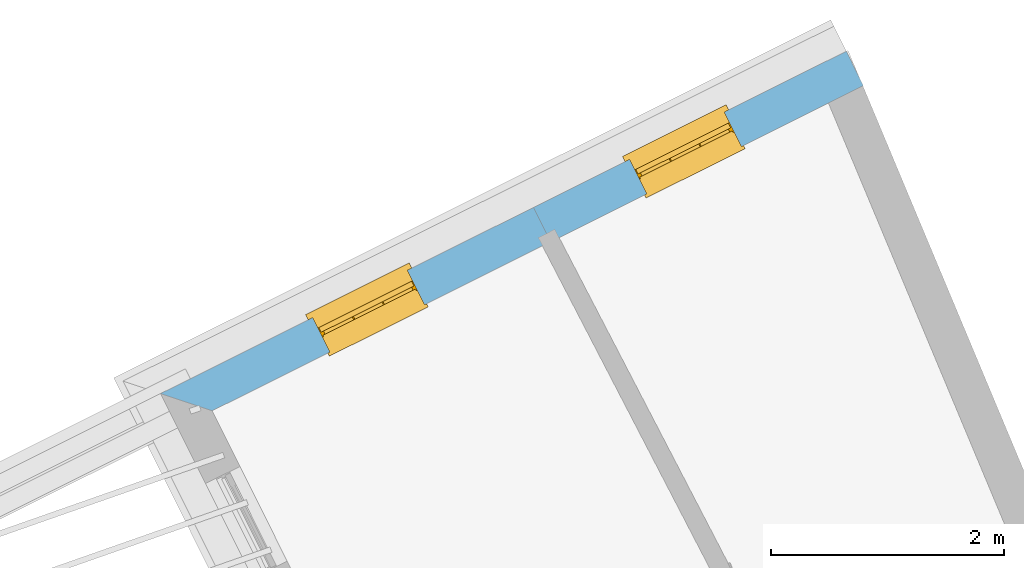
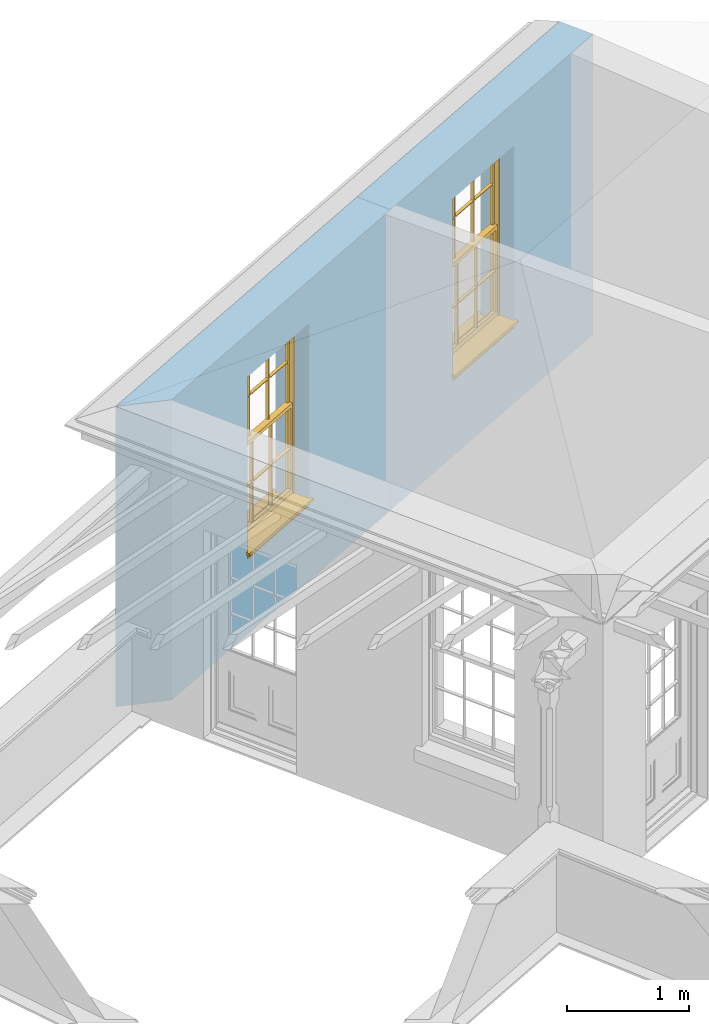
# One storey, part 5 of 7: 2 windows, 2 openings, plus 2 elements that do not belong to this part.
"""IFC2X3 building model written with IfcOpenShell, lengths in metres."""

from ifc_helpers import new_model, si_unit, frame, origin, place, context, subcontext, project, spatial, polyline, outline, extrude, faceted_brep, material, layer, layer_set, layer_usage, element, fill, save


model = new_model("IFC2X3")

# Units and contexts
model_context = context("Model", 3, world=origin())
body_context = subcontext(model_context, "Body", "Model", "MODEL_VIEW")
ifc_project = project(units=[si_unit("PLANEANGLEUNIT", "RADIAN"), si_unit("MASSUNIT", "GRAM", prefix="KILO"), si_unit("FORCEUNIT", "NEWTON", prefix="KILO"), si_unit("LENGTHUNIT", "METRE")], contexts=[model_context])

# Site, building, storey
site_placement = place(None, origin())
site = spatial("IfcSite", under=ifc_project, at=site_placement, CompositionType="ELEMENT")
building_placement = place(None, origin())
building = spatial("IfcBuilding", under=site, at=building_placement, Name="Building plot-8", CompositionType="ELEMENT")
storey_placement = place(None, frame((0.0, 0.0, 6.3)))
storey = spatial("IfcBuildingStorey", under=building, at=storey_placement, Name="Floor 2", CompositionType="ELEMENT", Elevation=6.3)

# Wall, opening, window
ifc_material = material(Name="Masonry")
ifc_layer = layer(ifc_material, 0.33, ventilated=False)
ifc_layer_set = layer_set([ifc_layer], Name="My Wall")
ifc_layer_usage = layer_usage(ifc_layer_set, "AXIS2", "NEGATIVE", 0.08)
wall_1_placement = place(storey_placement, origin())
wall_1 = element("IfcWallStandardCase", 1, at=wall_1_placement, inside=storey, material=ifc_layer_usage, Name="exterior", context=body_context, shape_type="SweptSolid", body=[
    extrude(outline(polyline([(28.1976396877446, 19.9353489269842), (28.0502378466283, 20.230599155156), (25.3643689149095, 18.889695786567), (25.5117707560258, 18.5944455583952), (28.1976396877446, 19.9353489269842)])), origin(), (0.0, 0.0, 1.0), 3.0),
])
opening_1_placement = place(storey_placement, frame((0.0, 0.0, 0.75)))
opening_1 = element("IfcOpeningElement", 2, at=opening_1_placement, cuts=wall_1, Name="Opening", ObjectType="Opening", context=body_context, shape_type="SweptSolid", body=[
    extrude(outline(polyline([(27.0025536089408, 19.7075493119778), (26.1883787373153, 19.3010775682935), (26.3357805784316, 19.0058273401217), (27.149955450057, 19.4122990838059), (27.0025536089408, 19.7075493119778)])), origin(), (0.0, 0.0, 1.0), 1.82),
])
window_1_placement = place(storey_placement, frame((27.1142216703925, 19.4838748966961, 0.75), z_axis=(0.0, 0.0, 1.0), x_axis=(-0.814174871625433, -0.406471743684243, 0.0)))
window_1 = element("IfcWindow", 3, at=window_1_placement, inside=storey, Name="bedroom outside window", OverallHeight=1.82, OverallWidth=0.91, context=body_context, shape_type="Brep", held_by="IfcProductRepresentation", body=[
    faceted_brep([(0.033125, -0.105, 0.975209), (0.01, -0.105, 0.975209), (0.033125, -0.105, 1.376042), (0.876875, -0.105, 0.975209), (0.876875, -0.105, 1.376042), (0.9, -0.105, 0.975209), (0.876875, -0.105, 1.386042), (0.876875, -0.105, 1.786875), (0.9, -0.105, 1.81), (0.033125, -0.105, 1.786875), (0.033125, -0.105, 1.386042), (0.01, -0.105, 1.81), (0.876875, -0.135, 1.376042), (0.876875, -0.135, 0.975209), (0.9, -0.135, 0.937083), (0.033125, -0.135, 1.786875), (0.01, -0.135, 1.81), (0.033125, -0.135, 1.386042), (0.01, -0.135, 0.937083), (0.033125, -0.135, 0.975209), (0.033125, -0.135, 1.376042), (0.876875, -0.135, 1.786875), (0.876875, -0.135, 1.386042), (0.9, -0.135, 1.81), (0.033125, -0.105, 0.937083), (0.01, -0.105, 0.937083), (0.033125, -0.105, 0.53625), (0.876875, -0.105, 0.937083), (0.876875, -0.105, 0.53625), (0.9, -0.105, 0.937083), (0.876875, -0.105, 0.52625), (0.876875, -0.105, 0.125417), (0.9, -0.105, 0.077167), (0.033125, -0.105, 0.125417), (0.033125, -0.105, 0.52625), (0.01, -0.105, 0.077167), (-0.0425, -0.25, 0.01), (-0.0425, -0.3, 0.001667), (0.0, -0.25, 0.01), (0.9525, -0.25, 0.01), (0.91, -0.25, 0.01), (0.9525, -0.3, 0.001667), (-0.02, 0.08, 0.077167), (0.0, 0.08, 0.077167), (-0.02, 0.11, 0.077167), (0.0, -0.06, 0.077167), (0.01, -0.06, 0.077167), (0.91, -0.06, 0.077167), (0.91, 0.08, 0.077167), (0.9, -0.06, 0.077167), (0.93, 0.08, 0.077167), (0.93, 0.11, 0.077167), (0.01, -0.075, 0.975209), (0.9, -0.075, 0.975209), (0.876875, -0.075, 0.125417), (0.876875, -0.075, 0.52625), (0.9, -0.075, 0.077167), (0.876875, -0.075, 0.53625), (0.876875, -0.075, 0.937083), (0.033125, -0.075, 0.125417), (0.01, -0.075, 0.077167), (0.033125, -0.075, 0.52625), (0.033125, -0.075, 0.937083), (0.033125, -0.075, 0.53625), (-0.02, 0.08, 0.052167), (-0.02, 0.11, 0.052167), (0.93, 0.11, 0.052167), (0.93, 0.08, 0.052167), (0.91, 0.08, 0.052167), (0.0, 0.08, 0.052167), (0.91, -0.15, 0.026667), (0.0, -0.15, 0.026667), (-0.0425, -0.3, -0.123333), (0.9525, -0.3, -0.123333), (-0.0425, -0.25, -0.123333), (0.9525, -0.25, -0.123333), (0.01, -0.06, 1.81), (0.9, -0.06, 1.81), (0.0, -0.06, 1.82), (0.91, -0.06, 1.82), (0.01, -0.15, 0.077167), (0.9, -0.15, 0.077167), (0.592292, -0.105, 0.125417), (0.592292, -0.075, 0.125417), (0.317708, -0.075, 0.125417), (0.317708, -0.105, 0.125417), (0.592292, -0.105, 0.53625), (0.317708, -0.105, 0.53625), (0.317708, -0.105, 0.52625), (0.592292, -0.105, 0.52625), (0.592292, -0.075, 0.53625), (0.317708, -0.075, 0.53625), (0.592292, -0.135, 1.386042), (0.592292, -0.105, 1.386042), (0.317708, -0.105, 1.386042), (0.317708, -0.135, 1.386042), (0.317708, -0.135, 1.376042), (0.592292, -0.135, 1.376042), (0.317708, -0.105, 1.376042), (0.592292, -0.105, 1.376042), (0.602292, -0.135, 1.376042), (0.592292, -0.135, 0.975209), (0.602292, -0.135, 0.975209), (0.602292, -0.105, 0.975209), (0.592292, -0.105, 0.975209), (0.602292, -0.105, 1.376042), (0.602292, -0.075, 0.53625), (0.602292, -0.105, 0.53625), (0.317708, -0.075, 0.52625), (0.307708, -0.075, 0.125417), (0.307708, -0.075, 0.52625), (0.602292, -0.075, 0.52625), (0.602292, -0.075, 0.125417), (0.592292, -0.075, 0.52625), (0.307708, -0.075, 0.53625), (0.317708, -0.075, 0.937083), (0.307708, -0.075, 0.937083), (0.602292, -0.075, 0.937083), (0.592292, -0.075, 0.937083), (0.307708, -0.105, 0.52625), (0.307708, -0.105, 0.125417), (0.307708, -0.105, 0.53625), (0.307708, -0.105, 0.937083), (0.592292, -0.105, 0.937083), (0.317708, -0.105, 0.937083), (0.602292, -0.105, 0.937083), (0.602292, -0.105, 0.52625), (0.602292, -0.105, 0.125417), (0.307708, -0.135, 1.386042), (0.307708, -0.135, 1.376042), (0.307708, -0.135, 0.975209), (0.317708, -0.135, 0.975209), (0.317708, -0.135, 1.786875), (0.307708, -0.135, 1.786875), (0.602292, -0.135, 1.786875), (0.592292, -0.135, 1.786875), (0.602292, -0.135, 1.386042), (0.602292, -0.105, 1.386042), (0.307708, -0.105, 1.386042), (0.307708, -0.105, 1.786875), (0.317708, -0.105, 1.786875), (0.592292, -0.105, 1.786875), (0.602292, -0.105, 1.786875), (0.307708, -0.105, 1.376042), (0.317708, -0.105, 0.975209), (0.307708, -0.105, 0.975209), (0.91, -0.15, 1.82), (0.9, -0.15, 1.81), (0.01, -0.15, 1.81), (0.0, -0.15, 1.82), (0.91, -0.25, 0.0), (0.0, -0.25, 0.0), (0.91, 0.08, 0.0), (0.0, 0.08, 0.0)], [[[0, 1, 2]], [[3, 4, 5]], [[6, 7, 8]], [[9, 10, 11]], [[12, 13, 14]], [[15, 16, 17]], [[18, 19, 20]], [[21, 22, 23]], [[24, 25, 26]], [[27, 28, 29]], [[30, 31, 32]], [[33, 34, 35]], [[14, 27, 29]], [[25, 24, 18]], [[36, 37, 38]], [[39, 40, 41]], [[42, 43, 44]], [[45, 46, 43]], [[47, 48, 49]], [[50, 51, 48]], [[1, 0, 52]], [[5, 53, 3]], [[54, 55, 56]], [[57, 58, 53]], [[59, 60, 61]], [[62, 63, 52]], [[48, 43, 46, 49]], [[51, 44, 43, 48]], [[64, 42, 44, 65]], [[65, 44, 51, 66]], [[66, 51, 50, 67]], [[65, 66, 68, 69]], [[60, 56, 49, 46]], [[70, 71, 38, 40]], [[37, 41, 40, 38]], [[37, 72, 73, 41]], [[74, 75, 73, 72]], [[8, 11, 76, 77]], [[76, 78, 79, 77]], [[32, 35, 80, 81]], [[81, 80, 71, 70]], [[82, 83, 84, 85]], [[86, 87, 88, 89]], [[86, 90, 91, 87]], [[92, 93, 94, 95]], [[92, 95, 96, 97]], [[96, 98, 99, 97]], [[100, 97, 101, 102]], [[103, 104, 99, 105]], [[97, 99, 104, 101]], [[102, 103, 105, 100]], [[28, 57, 106, 107]], [[108, 84, 109, 110]], [[111, 112, 83, 113]], [[114, 110, 61, 63]], [[90, 113, 108, 91]], [[115, 91, 114, 116]], [[117, 106, 90, 118]], [[111, 106, 57, 55]], [[119, 110, 109, 120]], [[34, 61, 110, 119]], [[89, 113, 83, 82]], [[88, 108, 113, 89]], [[85, 84, 108, 88]], [[121, 114, 63, 26]], [[122, 116, 114, 121]], [[123, 118, 90, 86]], [[87, 91, 115, 124]], [[107, 106, 117, 125]], [[126, 111, 55, 30]], [[127, 112, 111, 126]], [[126, 30, 28, 107]], [[88, 119, 120, 85]], [[126, 89, 82, 127]], [[125, 123, 86, 107]], [[121, 26, 34, 119]], [[124, 122, 121, 87]], [[128, 17, 20, 129]], [[96, 129, 130, 131]], [[132, 133, 128, 95]], [[134, 135, 92, 136]], [[100, 12, 22, 136]], [[137, 6, 4, 105]], [[94, 138, 139, 140]], [[137, 93, 141, 142]], [[99, 98, 94, 93]], [[143, 2, 10, 138]], [[144, 145, 143, 98]], [[129, 143, 145, 130]], [[20, 2, 143, 129]], [[131, 144, 98, 96]], [[128, 138, 10, 17]], [[133, 139, 138, 128]], [[135, 141, 93, 92]], [[95, 94, 140, 132]], [[22, 6, 137, 136]], [[136, 137, 142, 134]], [[100, 105, 4, 12]], [[107, 86, 89, 126]], [[106, 111, 113, 90]], [[91, 108, 110, 114]], [[87, 121, 119, 88]], [[97, 100, 136, 92]], [[129, 96, 95, 128]], [[98, 143, 138, 94]], [[105, 99, 93, 137]], [[131, 101, 104, 144]], [[124, 115, 118, 123]], [[132, 140, 141, 135]], [[120, 109, 59, 33]], [[15, 9, 139, 133]], [[134, 142, 7, 21]], [[31, 54, 112, 127]], [[36, 74, 72, 37]], [[39, 41, 73, 75]], [[18, 14, 101, 131]], [[23, 16, 132, 135]], [[83, 56, 60, 84]], [[52, 53, 118, 115]], [[53, 52, 144, 104]], [[11, 8, 141, 140]], [[14, 18, 124, 123]], [[2, 1, 11, 10]], [[8, 5, 4, 6]], [[57, 53, 56, 55]], [[60, 52, 63, 61]], [[26, 25, 35, 34]], [[32, 29, 28, 30]], [[14, 23, 22, 12]], [[18, 20, 17, 16]], [[19, 0, 2, 20]], [[17, 10, 9, 15]], [[12, 4, 3, 13]], [[21, 7, 6, 22]], [[27, 58, 57, 28]], [[30, 55, 54, 31]], [[33, 59, 61, 34]], [[26, 63, 62, 24]], [[5, 8, 77, 53]], [[76, 11, 1, 52]], [[46, 45, 78, 76]], [[49, 77, 79, 47]], [[70, 146, 147, 81]], [[71, 80, 148, 149]], [[19, 130, 145, 0]], [[102, 13, 3, 103]], [[116, 122, 24, 62]], [[29, 32, 81, 14]], [[80, 35, 25, 18]], [[60, 46, 76, 52]], [[77, 49, 56, 53]], [[23, 14, 81, 147]], [[16, 148, 80, 18]], [[35, 85, 120]], [[120, 33, 35]], [[127, 82, 32]], [[32, 31, 127]], [[32, 82, 85, 35]], [[102, 101, 14]], [[14, 13, 102]], [[18, 131, 130]], [[130, 19, 18]], [[134, 21, 23]], [[23, 135, 134]], [[16, 15, 133]], [[133, 132, 16]], [[11, 140, 139]], [[139, 9, 11]], [[142, 141, 8]], [[8, 7, 142]], [[23, 147, 148, 16]], [[146, 149, 148, 147]], [[52, 115, 116]], [[116, 62, 52]], [[118, 53, 117]], [[58, 117, 53]], [[27, 125, 117, 58]], [[56, 83, 112]], [[112, 54, 56]], [[109, 84, 60]], [[60, 59, 109]], [[125, 27, 14]], [[14, 123, 125]], [[122, 124, 18]], [[18, 24, 122]], [[145, 144, 52]], [[52, 0, 145]], [[103, 3, 53]], [[53, 104, 103]], [[79, 78, 149, 146]], [[78, 45, 71, 149]], [[146, 70, 47, 79]], [[150, 75, 74, 151]], [[68, 66, 67]], [[48, 68, 67, 50]], [[69, 64, 65]], [[42, 64, 69, 43]], [[69, 68, 152, 153]], [[70, 68, 48, 47]], [[150, 152, 68, 70]], [[43, 69, 71, 45]], [[69, 153, 151, 71]], [[152, 150, 151, 153]], [[38, 151, 74, 36]], [[71, 151, 38]], [[39, 75, 150, 40]], [[40, 150, 70]]]),
])
fill(opening_1, window_1)

wall_2_placement = place(storey_placement, origin())
wall_2 = element("IfcWallStandardCase", 4, at=wall_2_placement, inside=storey, material=ifc_layer_usage, Name="exterior", context=body_context, shape_type="SweptSolid", body=[
    extrude(outline(polyline([(25.5117707560258, 18.5944455583952), (25.3643689149095, 18.889695786567), (22.162338538902, 17.2911020254168), (22.6049906081901, 17.1432536383612), (25.5117707560258, 18.5944455583952)])), origin(), (0.0, 0.0, 1.0), 3.0),
])
opening_2_placement = place(storey_placement, frame((0.0, 0.0, 0.75)))
opening_2 = element("IfcOpeningElement", 5, at=opening_2_placement, cuts=wall_2, Name="Opening", ObjectType="Opening", context=body_context, shape_type="SweptSolid", body=[
    extrude(outline(polyline([(24.2822783703593, 18.3494688085599), (23.4681034987339, 17.9429970648756), (23.6155053398501, 17.6477468367038), (24.4296802114756, 18.054218580388), (24.2822783703593, 18.3494688085599)])), origin(), (0.0, 0.0, 1.0), 1.82),
])
window_2_placement = place(storey_placement, frame((24.393946431811, 18.1257943932782, 0.75), z_axis=(0.0, 0.0, 1.0), x_axis=(-0.814174871625433, -0.406471743684246, 0.0)))
window_2 = element("IfcWindow", 6, at=window_2_placement, inside=storey, Name="circulation outside window", OverallHeight=1.82, OverallWidth=0.91, context=body_context, shape_type="Brep", held_by="IfcProductRepresentation", body=[
    faceted_brep([(0.033125, -0.105, 0.975209), (0.01, -0.105, 0.975209), (0.033125, -0.105, 1.376042), (0.876875, -0.105, 0.975209), (0.876875, -0.105, 1.376042), (0.9, -0.105, 0.975209), (0.876875, -0.105, 1.386042), (0.876875, -0.105, 1.786875), (0.9, -0.105, 1.81), (0.033125, -0.105, 1.786875), (0.033125, -0.105, 1.386042), (0.01, -0.105, 1.81), (0.876875, -0.135, 1.376042), (0.876875, -0.135, 0.975209), (0.9, -0.135, 0.937083), (0.033125, -0.135, 1.786875), (0.01, -0.135, 1.81), (0.033125, -0.135, 1.386042), (0.01, -0.135, 0.937083), (0.033125, -0.135, 0.975209), (0.033125, -0.135, 1.376042), (0.876875, -0.135, 1.786875), (0.876875, -0.135, 1.386042), (0.9, -0.135, 1.81), (0.033125, -0.105, 0.937083), (0.01, -0.105, 0.937083), (0.033125, -0.105, 0.53625), (0.876875, -0.105, 0.937083), (0.876875, -0.105, 0.53625), (0.9, -0.105, 0.937083), (0.876875, -0.105, 0.52625), (0.876875, -0.105, 0.125417), (0.9, -0.105, 0.077167), (0.033125, -0.105, 0.125417), (0.033125, -0.105, 0.52625), (0.01, -0.105, 0.077167), (-0.0425, -0.25, 0.01), (-0.0425, -0.3, 0.001667), (0.0, -0.25, 0.01), (0.9525, -0.25, 0.01), (0.91, -0.25, 0.01), (0.9525, -0.3, 0.001667), (-0.02, 0.08, 0.077167), (0.0, 0.08, 0.077167), (-0.02, 0.11, 0.077167), (0.0, -0.06, 0.077167), (0.01, -0.06, 0.077167), (0.91, -0.06, 0.077167), (0.91, 0.08, 0.077167), (0.9, -0.06, 0.077167), (0.93, 0.08, 0.077167), (0.93, 0.11, 0.077167), (0.01, -0.075, 0.975209), (0.9, -0.075, 0.975209), (0.876875, -0.075, 0.125417), (0.876875, -0.075, 0.52625), (0.9, -0.075, 0.077167), (0.876875, -0.075, 0.53625), (0.876875, -0.075, 0.937083), (0.033125, -0.075, 0.125417), (0.01, -0.075, 0.077167), (0.033125, -0.075, 0.52625), (0.033125, -0.075, 0.937083), (0.033125, -0.075, 0.53625), (-0.02, 0.08, 0.052167), (-0.02, 0.11, 0.052167), (0.93, 0.11, 0.052167), (0.93, 0.08, 0.052167), (0.91, 0.08, 0.052167), (0.0, 0.08, 0.052167), (0.91, -0.15, 0.026667), (0.0, -0.15, 0.026667), (-0.0425, -0.3, -0.123333), (0.9525, -0.3, -0.123333), (-0.0425, -0.25, -0.123333), (0.9525, -0.25, -0.123333), (0.01, -0.06, 1.81), (0.9, -0.06, 1.81), (0.0, -0.06, 1.82), (0.91, -0.06, 1.82), (0.01, -0.15, 0.077167), (0.9, -0.15, 0.077167), (0.592292, -0.105, 0.125417), (0.592292, -0.075, 0.125417), (0.317708, -0.075, 0.125417), (0.317708, -0.105, 0.125417), (0.592292, -0.105, 0.53625), (0.317708, -0.105, 0.53625), (0.317708, -0.105, 0.52625), (0.592292, -0.105, 0.52625), (0.592292, -0.075, 0.53625), (0.317708, -0.075, 0.53625), (0.592292, -0.135, 1.386042), (0.592292, -0.105, 1.386042), (0.317708, -0.105, 1.386042), (0.317708, -0.135, 1.386042), (0.317708, -0.135, 1.376042), (0.592292, -0.135, 1.376042), (0.317708, -0.105, 1.376042), (0.592292, -0.105, 1.376042), (0.602292, -0.135, 1.376042), (0.592292, -0.135, 0.975209), (0.602292, -0.135, 0.975209), (0.602292, -0.105, 0.975209), (0.592292, -0.105, 0.975209), (0.602292, -0.105, 1.376042), (0.602292, -0.075, 0.53625), (0.602292, -0.105, 0.53625), (0.317708, -0.075, 0.52625), (0.307708, -0.075, 0.125417), (0.307708, -0.075, 0.52625), (0.602292, -0.075, 0.52625), (0.602292, -0.075, 0.125417), (0.592292, -0.075, 0.52625), (0.307708, -0.075, 0.53625), (0.317708, -0.075, 0.937083), (0.307708, -0.075, 0.937083), (0.602292, -0.075, 0.937083), (0.592292, -0.075, 0.937083), (0.307708, -0.105, 0.52625), (0.307708, -0.105, 0.125417), (0.307708, -0.105, 0.53625), (0.307708, -0.105, 0.937083), (0.592292, -0.105, 0.937083), (0.317708, -0.105, 0.937083), (0.602292, -0.105, 0.937083), (0.602292, -0.105, 0.52625), (0.602292, -0.105, 0.125417), (0.307708, -0.135, 1.386042), (0.307708, -0.135, 1.376042), (0.307708, -0.135, 0.975209), (0.317708, -0.135, 0.975209), (0.317708, -0.135, 1.786875), (0.307708, -0.135, 1.786875), (0.602292, -0.135, 1.786875), (0.592292, -0.135, 1.786875), (0.602292, -0.135, 1.386042), (0.602292, -0.105, 1.386042), (0.307708, -0.105, 1.386042), (0.307708, -0.105, 1.786875), (0.317708, -0.105, 1.786875), (0.592292, -0.105, 1.786875), (0.602292, -0.105, 1.786875), (0.307708, -0.105, 1.376042), (0.317708, -0.105, 0.975209), (0.307708, -0.105, 0.975209), (0.91, -0.15, 1.82), (0.9, -0.15, 1.81), (0.01, -0.15, 1.81), (0.0, -0.15, 1.82), (0.91, -0.25, 0.0), (0.0, -0.25, 0.0), (0.91, 0.08, 0.0), (0.0, 0.08, 0.0)], [[[0, 1, 2]], [[3, 4, 5]], [[6, 7, 8]], [[9, 10, 11]], [[12, 13, 14]], [[15, 16, 17]], [[18, 19, 20]], [[21, 22, 23]], [[24, 25, 26]], [[27, 28, 29]], [[30, 31, 32]], [[33, 34, 35]], [[14, 27, 29]], [[25, 24, 18]], [[36, 37, 38]], [[39, 40, 41]], [[42, 43, 44]], [[45, 46, 43]], [[47, 48, 49]], [[50, 51, 48]], [[1, 0, 52]], [[5, 53, 3]], [[54, 55, 56]], [[57, 58, 53]], [[59, 60, 61]], [[62, 63, 52]], [[48, 43, 46, 49]], [[51, 44, 43, 48]], [[64, 42, 44, 65]], [[65, 44, 51, 66]], [[66, 51, 50, 67]], [[65, 66, 68, 69]], [[60, 56, 49, 46]], [[70, 71, 38, 40]], [[37, 41, 40, 38]], [[37, 72, 73, 41]], [[74, 75, 73, 72]], [[8, 11, 76, 77]], [[76, 78, 79, 77]], [[32, 35, 80, 81]], [[81, 80, 71, 70]], [[82, 83, 84, 85]], [[86, 87, 88, 89]], [[86, 90, 91, 87]], [[92, 93, 94, 95]], [[92, 95, 96, 97]], [[96, 98, 99, 97]], [[100, 97, 101, 102]], [[103, 104, 99, 105]], [[97, 99, 104, 101]], [[102, 103, 105, 100]], [[28, 57, 106, 107]], [[108, 84, 109, 110]], [[111, 112, 83, 113]], [[114, 110, 61, 63]], [[90, 113, 108, 91]], [[115, 91, 114, 116]], [[117, 106, 90, 118]], [[111, 106, 57, 55]], [[119, 110, 109, 120]], [[34, 61, 110, 119]], [[89, 113, 83, 82]], [[88, 108, 113, 89]], [[85, 84, 108, 88]], [[121, 114, 63, 26]], [[122, 116, 114, 121]], [[123, 118, 90, 86]], [[87, 91, 115, 124]], [[107, 106, 117, 125]], [[126, 111, 55, 30]], [[127, 112, 111, 126]], [[126, 30, 28, 107]], [[88, 119, 120, 85]], [[126, 89, 82, 127]], [[125, 123, 86, 107]], [[121, 26, 34, 119]], [[124, 122, 121, 87]], [[128, 17, 20, 129]], [[96, 129, 130, 131]], [[132, 133, 128, 95]], [[134, 135, 92, 136]], [[100, 12, 22, 136]], [[137, 6, 4, 105]], [[94, 138, 139, 140]], [[137, 93, 141, 142]], [[99, 98, 94, 93]], [[143, 2, 10, 138]], [[144, 145, 143, 98]], [[129, 143, 145, 130]], [[20, 2, 143, 129]], [[131, 144, 98, 96]], [[128, 138, 10, 17]], [[133, 139, 138, 128]], [[135, 141, 93, 92]], [[95, 94, 140, 132]], [[22, 6, 137, 136]], [[136, 137, 142, 134]], [[100, 105, 4, 12]], [[107, 86, 89, 126]], [[106, 111, 113, 90]], [[91, 108, 110, 114]], [[87, 121, 119, 88]], [[97, 100, 136, 92]], [[129, 96, 95, 128]], [[98, 143, 138, 94]], [[105, 99, 93, 137]], [[131, 101, 104, 144]], [[124, 115, 118, 123]], [[132, 140, 141, 135]], [[120, 109, 59, 33]], [[15, 9, 139, 133]], [[134, 142, 7, 21]], [[31, 54, 112, 127]], [[36, 74, 72, 37]], [[39, 41, 73, 75]], [[18, 14, 101, 131]], [[23, 16, 132, 135]], [[83, 56, 60, 84]], [[52, 53, 118, 115]], [[53, 52, 144, 104]], [[11, 8, 141, 140]], [[14, 18, 124, 123]], [[2, 1, 11, 10]], [[8, 5, 4, 6]], [[57, 53, 56, 55]], [[60, 52, 63, 61]], [[26, 25, 35, 34]], [[32, 29, 28, 30]], [[14, 23, 22, 12]], [[18, 20, 17, 16]], [[19, 0, 2, 20]], [[17, 10, 9, 15]], [[12, 4, 3, 13]], [[21, 7, 6, 22]], [[27, 58, 57, 28]], [[30, 55, 54, 31]], [[33, 59, 61, 34]], [[26, 63, 62, 24]], [[5, 8, 77, 53]], [[76, 11, 1, 52]], [[46, 45, 78, 76]], [[49, 77, 79, 47]], [[70, 146, 147, 81]], [[71, 80, 148, 149]], [[19, 130, 145, 0]], [[102, 13, 3, 103]], [[116, 122, 24, 62]], [[29, 32, 81, 14]], [[80, 35, 25, 18]], [[60, 46, 76, 52]], [[77, 49, 56, 53]], [[23, 14, 81, 147]], [[16, 148, 80, 18]], [[35, 85, 120]], [[120, 33, 35]], [[127, 82, 32]], [[32, 31, 127]], [[32, 82, 85, 35]], [[102, 101, 14]], [[14, 13, 102]], [[18, 131, 130]], [[130, 19, 18]], [[134, 21, 23]], [[23, 135, 134]], [[16, 15, 133]], [[133, 132, 16]], [[11, 140, 139]], [[139, 9, 11]], [[142, 141, 8]], [[8, 7, 142]], [[23, 147, 148, 16]], [[146, 149, 148, 147]], [[52, 115, 116]], [[116, 62, 52]], [[118, 53, 117]], [[58, 117, 53]], [[27, 125, 117, 58]], [[56, 83, 112]], [[112, 54, 56]], [[109, 84, 60]], [[60, 59, 109]], [[125, 27, 14]], [[14, 123, 125]], [[122, 124, 18]], [[18, 24, 122]], [[145, 144, 52]], [[52, 0, 145]], [[103, 3, 53]], [[53, 104, 103]], [[79, 78, 149, 146]], [[78, 45, 71, 149]], [[146, 70, 47, 79]], [[150, 75, 74, 151]], [[68, 66, 67]], [[48, 68, 67, 50]], [[69, 64, 65]], [[42, 64, 69, 43]], [[69, 68, 152, 153]], [[70, 68, 48, 47]], [[150, 152, 68, 70]], [[43, 69, 71, 45]], [[69, 153, 151, 71]], [[152, 150, 151, 153]], [[38, 151, 74, 36]], [[71, 151, 38]], [[39, 75, 150, 40]], [[40, 150, 70]]]),
])
fill(opening_2, window_2)

save(model, "model.ifc")
